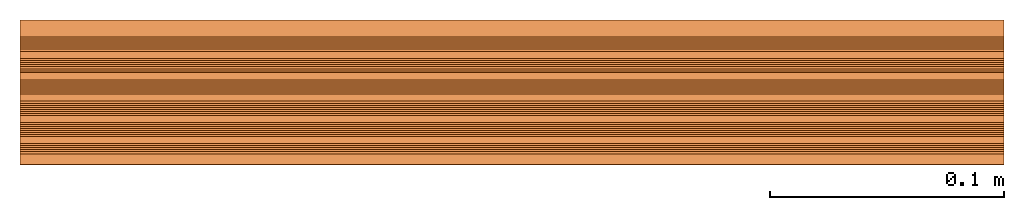
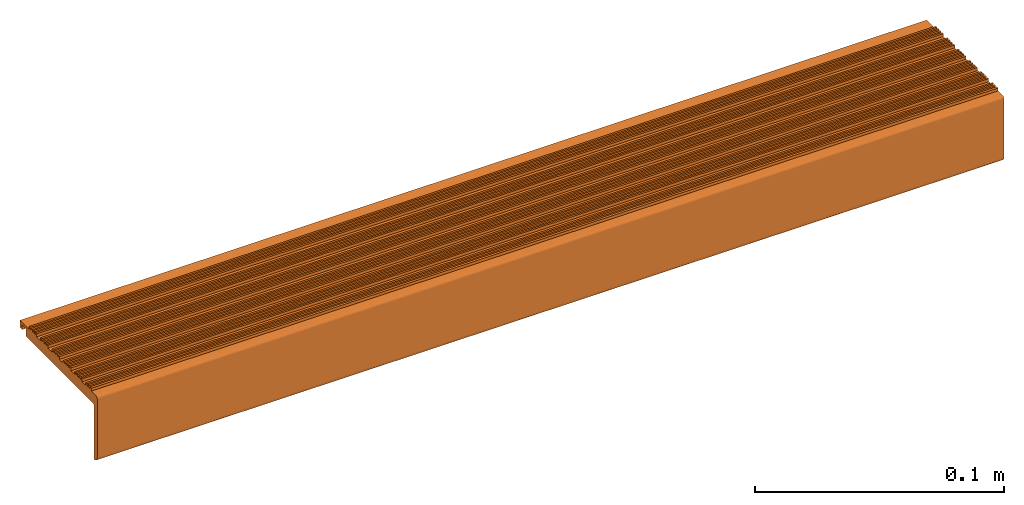
# One storey: 1 proxy.
"""IFC2X3 building model written with IfcOpenShell, lengths in millimetres."""

from ifc_helpers import new_model, entity, si_unit, converted_unit, derived_unit, direction, frame, frame_2d, origin, place, context, subcontext, project, spatial, polyline, circle_curve, parameter, trimmed, segment, composite_curve, outline, extrude, source, transform, mapped, material, material_list, type_object, type_shapes, element, save


model = new_model("IFC2X3")

# Units and contexts
model_context = context("Model", 3, precision=0.01, world=origin(), true_north=direction((6.12303176911189e-17, 1.0)))
body_context = subcontext(model_context, "Body", "Model", "MODEL_VIEW")
ifc_project = project(units=[si_unit("LENGTHUNIT", "METRE", prefix="MILLI"), si_unit("AREAUNIT", "SQUARE_METRE"), si_unit("VOLUMEUNIT", "CUBIC_METRE"), converted_unit("PLANEANGLEUNIT", "DEGREE", entity("IfcRatioMeasure", 0.0174532925199433), si_unit("PLANEANGLEUNIT", "RADIAN"), dimensions=[0, 0, 0, 0, 0, 0, 0]), si_unit("MASSUNIT", "GRAM", prefix="KILO"), derived_unit("MASSDENSITYUNIT", [(si_unit("MASSUNIT", "GRAM", prefix="KILO"), 1), (si_unit("LENGTHUNIT", "METRE"), -3)]), si_unit("TIMEUNIT", "SECOND"), si_unit("FREQUENCYUNIT", "HERTZ"), si_unit("THERMODYNAMICTEMPERATUREUNIT", "DEGREE_CELSIUS"), derived_unit("THERMALTRANSMITTANCEUNIT", [(si_unit("MASSUNIT", "GRAM", prefix="KILO"), 1), (si_unit("THERMODYNAMICTEMPERATUREUNIT", "KELVIN"), -1), (si_unit("TIMEUNIT", "SECOND"), -3)]), derived_unit("VOLUMETRICFLOWRATEUNIT", [(si_unit("LENGTHUNIT", "METRE"), 3), (si_unit("TIMEUNIT", "SECOND"), -1)]), si_unit("ELECTRICCURRENTUNIT", "AMPERE"), si_unit("ELECTRICVOLTAGEUNIT", "VOLT"), si_unit("POWERUNIT", "WATT"), si_unit("FORCEUNIT", "NEWTON", prefix="KILO"), si_unit("ILLUMINANCEUNIT", "LUX"), si_unit("LUMINOUSFLUXUNIT", "LUMEN"), si_unit("LUMINOUSINTENSITYUNIT", "CANDELA"), derived_unit("USERDEFINED", [(si_unit("MASSUNIT", "GRAM", prefix="KILO"), -1), (si_unit("LENGTHUNIT", "METRE"), -2), (si_unit("TIMEUNIT", "SECOND"), 3), (si_unit("LUMINOUSFLUXUNIT", "LUMEN"), 1)]), derived_unit("LINEARVELOCITYUNIT", [(si_unit("LENGTHUNIT", "METRE"), 1), (si_unit("TIMEUNIT", "SECOND"), -1)]), si_unit("PRESSUREUNIT", "PASCAL"), derived_unit("USERDEFINED", [(si_unit("LENGTHUNIT", "METRE"), -2), (si_unit("MASSUNIT", "GRAM", prefix="KILO"), 1), (si_unit("TIMEUNIT", "SECOND"), -2)])], contexts=[model_context])

# Site, building, storey
site_placement = place(None, origin())
site = spatial("IfcSite", under=ifc_project, at=site_placement, CompositionType="ELEMENT")
building_placement = place(site_placement, origin())
building = spatial("IfcBuilding", under=site, at=building_placement, CompositionType="ELEMENT")
storey_placement = place(building_placement, origin())
storey = spatial("IfcBuildingStorey", under=building, at=storey_placement, Name="Level 1", CompositionType="ELEMENT", Elevation=0.0)

# Proxy
ifc_material_1 = material()
ifc_material_2 = material()
ifc_material_list_1 = material_list([ifc_material_1, ifc_material_2])
ifc_material_list_2 = material_list([ifc_material_1, ifc_material_2])
building_element_proxy_type = type_object("IfcBuildingElementProxyType", PredefinedType="USERDEFINED", material=ifc_material_list_2)
shared_shape = source(origin(), body_context, "Body", "SweptSolid", [
    extrude(outline(polyline([(-24.75602922258, -0.551082198059412), (-23.8729771305574, -0.551082198059412), (-23.8729771305574, 0.32748543693918), (-23.0247049312485, 0.32748543693918), (-23.0247049312485, -0.551082198059412), (-22.1416528392259, -0.551082198059412), (-22.1416528392259, 0.327485436939163), (-21.2933806399169, 0.327485436939163), (-21.2933806399169, -0.551082198059412), (-20.4103285478944, -0.551082198059412), (-20.4103285478944, 0.327485436939146), (-19.5620563485854, 0.327485436939146), (-19.5620563485854, -0.551082198059412), (-18.6497463865112, -0.551082198059412), (-18.6497463865112, 0.866184572032178), (-15.5364410995923, 0.866184572032178), (-15.5364410995923, -0.551082198059509), (-14.6533890075698, -0.551082198059509), (-14.6533890075698, 0.327485436939089), (-13.8051168082608, 0.327485436939089), (-13.8051168082608, -0.551082198059509), (-12.9220647162382, -0.551082198059509), (-12.9220647162382, 0.32748543693907), (-12.0737925169293, 0.32748543693907), (-12.0737925169293, -0.551082198059509), (-11.1907404249067, -0.551082198059509), (-11.1907404249067, 0.327485436939053), (-10.3424682255978, 0.327485436939053), (-10.3424682255978, -0.551082198059509), (-9.52260260700914, -0.551082198059509), (-9.52260260700914, 0.86618457203227), (-6.46155694665484, 0.86618457203227), (-6.46155694665484, -0.551082198059579), (-5.57850485463227, -0.551082198059579), (-5.57850485463227, 0.327485436938997), (-4.73023265532332, 0.327485436938997), (-4.73023265532332, -0.551082198059579), (-3.84718056330076, -0.551082198059579), (-3.84718056330076, 0.327485436938974), (-2.9989083639918, 0.327485436938974), (-2.9989083639918, -0.551082198059579), (-2.11585627196924, -0.551082198059579), (-2.11585627196924, 0.327485436938956), (-1.26758407266028, 0.327485436938956), (-1.26758407266028, -0.551082198059614), (-0.358431946654845, -0.551082198059614), (-0.358431946654845, 0.86618457203236), (2.67141934943292, 0.86618457203236), (2.67141934943292, -0.551082198059653), (3.55447144145548, -0.551082198059653), (3.55447144145548, 0.3274854369389), (4.40274364076443, 0.3274854369389), (4.40274364076443, -0.551082198059653), (5.28579573278699, -0.551082198059653), (5.28579573278699, 0.327485436938882), (6.13406793209595, 0.327485436938882), (6.13406793209595, -0.551082198059653), (7.01712002411851, -0.551082198059653), (7.01712002411851, 0.327485436938865), (7.86539222342747, 0.327485436938865), (7.86539222342747, -0.551082198059705), (8.78341569886584, -0.551082198059705), (8.78341569886584, 0.866184572032453), (11.7082442160699, 0.866184572032453), (11.7082442160699, -0.551082198059744), (12.5912963080925, -0.551082198059744), (12.5912963080925, 0.327485436938809), (13.4395685074014, 0.327485436938809), (13.4395685074014, -0.551082198059744), (14.322620599424, -0.551082198059744), (14.322620599424, 0.327485436938791), (15.1708927987329, 0.327485436938791), (15.1708927987329, -0.551082198059744), (16.0539448907555, -0.551082198059744), (16.0539448907555, 0.327485436938774), (16.9022170900645, 0.327485436938774), (16.9022170900645, -0.551082198059796), (17.7421155655029, -0.551082198059796), (17.7421155655029, 0.866184572032544), (20.7070097964064, 0.866184572032544), (20.7070097964064, -0.551082198059829), (21.590061888429, -0.551082198059829), (21.590061888429, 0.327485436938719), (22.4383340877379, 0.327485436938719), (22.4383340877379, -0.551082198059829), (23.3213861797605, -0.551082198059829), (23.3213861797605, 0.327485436938706), (24.1696583790694, 0.327485436938706), (24.1696583790694, -0.551082198059829), (25.2439707774164, -0.551082198059829), (25.2439707774164, 2.77671526724737), (-24.75602922258, 2.77671526724753), (-24.75602922258, -0.551082198059412)])), frame((0.0, 28.4944120263147, 5.86618457204449), z_axis=(1.0, 0.0, 0.0), x_axis=(0.0, -1.0, 0.0)), (0.0, 0.0, 1.0), 420.0),
    extrude(outline(composite_curve([segment(polyline([(-26.799407304888, 0.74577978399964), (26.5542162687061, 0.74577978399964)]), True, "CONTINUOUS"), segment(polyline([(26.5542162687061, 0.74577978399964), (26.5542162687061, 4.54577978404281)]), True, "CONTINUOUS"), segment(polyline([(26.5542162687061, 4.54577978404281), (29.7705218439581, 4.54577978404274)]), True, "CONTINUOUS"), segment(polyline([(29.7705218439581, 4.54577978404274), (29.7705218439581, 2.24577978404274)]), True, "CONTINUOUS"), segment(polyline([(29.7705218439581, 2.24577978404274), (31.554216268706, 2.24577978404273)]), True, "CONTINUOUS"), segment(polyline([(31.554216268706, 2.24577978404273), (31.554216268706, 5.74577978405657)]), True, "CONTINUOUS"), segment(polyline([(31.554216268706, 5.74577978405657), (24.304657517609, 5.7457797840427)]), True, "CONTINUOUS"), segment(polyline([(24.304657517609, 5.7457797840427), (24.3046575176127, 3.83524908884117)]), True, "CONTINUOUS"), segment(polyline([(24.3046575176127, 3.83524908884117), (-25.6953424823873, 3.83524908884133)]), True, "CONTINUOUS"), segment(polyline([(-25.6953424823873, 3.83524908884133), (-25.6953424823873, 5.74577978404235)]), True, "CONTINUOUS"), segment(polyline([(-25.6953424823873, 5.74577978404235), (-29.4212712317152, 5.74577978407081)]), True, "CONTINUOUS"), segment(trimmed(circle_curve(frame_2d((-29.4212712317152, 4.73490459875958), x_axis=(1.0, 0.0)), 1.01087518531123), [parameter(89.9999999999998)], [parameter(180.0)], True, "PARAMETER"), True, "CONTINUOUS"), segment(polyline([(-30.432146416998, 4.73490459875958), (-30.432146416998, -23.8087252615486)]), True, "CONTINUOUS"), segment(trimmed(circle_curve(frame_2d((-27.9866514626031, -23.8087252615486), x_axis=(1.0, 0.0)), 2.4454949543949), [parameter(180.0)], [parameter(270.957539298929)], True, "PARAMETER"), True, "CONTINUOUS"), segment(polyline([(-27.9457837312941, -26.2538787128699), (-27.9457837312941, -0.400596642406394)]), True, "CONTINUOUS"), segment(trimmed(circle_curve(frame_2d((-26.799407304888, -0.400596642406394), x_axis=(1.0, 0.0)), 1.14637642640603), [parameter(90.0000000000005)], [parameter(180.0)], True, "PARAMETER"), False, "CONTINUOUS")], self_intersect=False)), frame((0.0, 28.9457837312856, -0.745779784044211), z_axis=(1.0, 0.0, 0.0), x_axis=(0.0, 1.0, 0.0)), (0.0, 0.0, 1.0), 420.0),
])
type_shapes(building_element_proxy_type, [shared_shape])
proxy_placement = place(storey_placement, frame((-210.0, -1.0, 0.0)))
element("IfcBuildingElementProxy", 1, at=proxy_placement, inside=storey, type_object=building_element_proxy_type, material=ifc_material_list_1, context=body_context, shape_type="MappedRepresentation", body=[
    mapped(shared_shape, transform((0.0, 0.0, 0.0), scale=1.0)),
])

save(model, "model.ifc")
